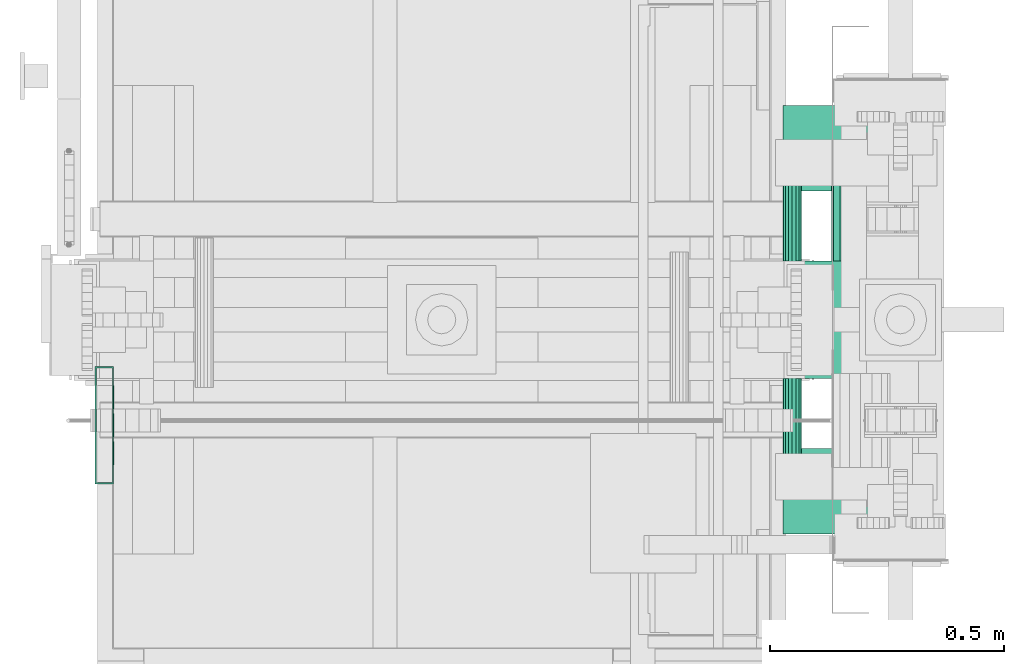
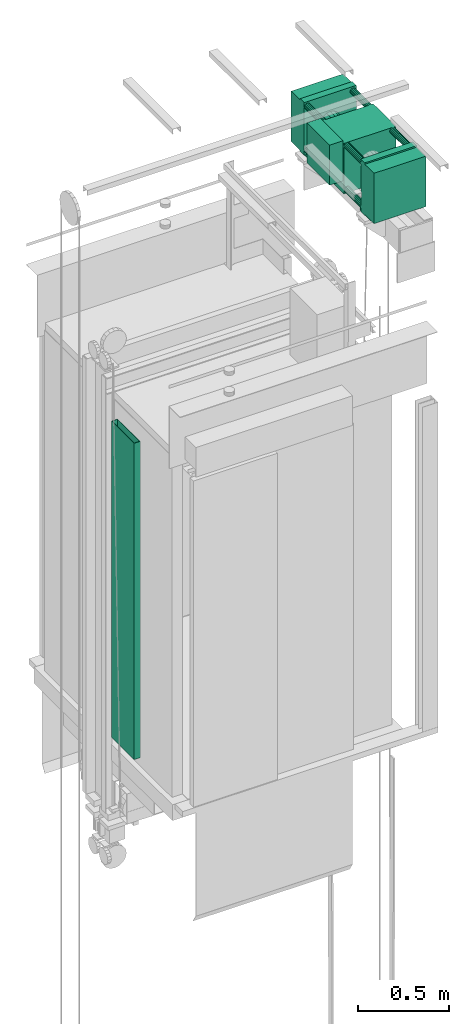
# One storey, part 3 of 13: 1 electric motor, 1 switching device.
"""IFC4 building model written with IfcOpenShell, lengths in millimetres."""

from ifc_helpers import new_model, entity, si_unit, converted_unit, frame, origin_with_axes, place, context, subcontext, project, spatial, faceted_brep, element, save


model = new_model("IFC4")

# Units and contexts
context_of_model = context(None, 3, precision=0.01, world=origin_with_axes())
sub_context_1 = subcontext(context_of_model, None, None, "MODEL_VIEW")
sub_context_2 = subcontext(context_of_model, None, None, "MODEL_VIEW")
ifc_project = project(units=[converted_unit("PLANEANGLEUNIT", "degree", entity("IfcPlaneAngleMeasure", 0.017453292519943), si_unit("PLANEANGLEUNIT", "RADIAN"), dimensions=[0, 0, 0, 0, 0, 0, 0]), si_unit("LENGTHUNIT", "METRE", prefix="MILLI"), si_unit("MASSUNIT", "GRAM", prefix="KILO"), converted_unit("TIMEUNIT", "year", entity("IfcTimeMeasure", 31557600.0), si_unit("TIMEUNIT", "SECOND"), dimensions=[0, 0, 1, 0, 0, 0, 0]), si_unit("THERMODYNAMICTEMPERATUREUNIT", "DEGREE_CELSIUS"), si_unit("AREAUNIT", "SQUARE_METRE"), si_unit("FORCEUNIT", "NEWTON"), si_unit("VOLUMEUNIT", "CUBIC_METRE"), si_unit("PRESSUREUNIT", "PASCAL"), si_unit("SOLIDANGLEUNIT", "STERADIAN")], contexts=[context_of_model])

# Site, building, storey
site = spatial("IfcSite", under=ifc_project)
building = spatial("IfcBuilding", under=site, Name="Document")
placement = place(None, origin_with_axes())
storey_placement = place(placement, frame((0.0, 0.0, -26400.0), z_axis=(0.0, 0.0, 1.0), x_axis=(1.0, 0.0, 0.0)))
storey = spatial("IfcBuildingStorey", under=building, at=storey_placement, Name="Z -26400", Elevation=-26400.0)

# Switching device
switching_device_placement = place(storey_placement, frame((200.0, 800.0, 31274.0), z_axis=(0.0, 0.0, 1.0), x_axis=(0.0, 1.0, 0.0)))
element("IfcSwitchingDevice", 1, at=switching_device_placement, inside=storey, context=sub_context_1, shape_type="Brep", body=[
    faceted_brep([(-85.0, -0.25, 1491.5), (-85.0, 0.0, 1491.5), (-85.0, 0.0, 1456.5), (-85.0, -0.25, 1456.5), (-35.0, -0.25, 1491.5), (-35.0, -0.25, 1456.5), (-35.0, 0.0, 1456.5), (-35.0, 0.0, 1491.5)], [[[0, 1, 2, 3]], [[4, 5, 6, 7]], [[0, 3, 5, 4]], [[3, 2, 6, 5]], [[2, 1, 7, 6]], [[1, 0, 4, 7]]]),
    faceted_brep([(-125.0, 20.0, 2133.0), (-122.0, 20.0, 2133.0), (-122.0, 20.0, 0.0), (-125.0, 20.0, 0.0), (-122.0, 3.0, 2133.0), (122.0, 3.0, 2133.0), (122.0, 3.0, 0.0), (-122.0, 3.0, 0.0), (125.0, 0.0, 0.0), (125.0, 0.0, 2133.0), (-125.0, 0.0, 2133.0), (-125.0, 0.0, 0.0), (122.0, 20.0, 2133.0), (125.0, 20.0, 2133.0), (125.0, 20.0, 0.0), (122.0, 20.0, 0.0)], [[[0, 1, 2, 3]], [[4, 5, 6, 7]], [[8, 9, 10, 11]], [[12, 13, 14, 15]], [[11, 10, 0, 3]], [[1, 4, 7, 2]], [[6, 5, 12, 15]], [[13, 9, 8, 14]], [[2, 7, 6, 15, 14, 8, 11, 3]], [[10, 9, 13, 12, 5, 4, 1, 0]]]),
    faceted_brep([(35.0, -0.25, 1491.5), (35.0, 0.0, 1491.5), (35.0, 0.0, 1456.5), (35.0, -0.25, 1456.5), (85.0, -0.25, 1491.5), (85.0, -0.25, 1456.5), (85.0, 0.0, 1456.5), (85.0, 0.0, 1491.5)], [[[0, 1, 2, 3]], [[4, 5, 6, 7]], [[0, 3, 5, 4]], [[3, 2, 6, 5]], [[2, 1, 7, 6]], [[1, 0, 4, 7]]]),
    faceted_brep([(-125.0, 40.0, 2133.0), (125.0, 40.0, 2133.0), (125.0, 40.0, 0.0), (-125.0, 40.0, 0.0), (122.0, 37.0, 0.0), (122.0, 37.0, 2133.0), (-122.0, 37.0, 2133.0), (-122.0, 37.0, 0.0), (-122.0, 20.0, 0.0), (-122.0, 20.0, 2133.0), (-125.0, 20.0, 2133.0), (-125.0, 20.0, 0.0), (125.0, 20.0, 0.0), (125.0, 20.0, 2133.0), (122.0, 20.0, 2133.0), (122.0, 20.0, 0.0)], [[[0, 1, 2, 3]], [[4, 5, 6, 7]], [[8, 9, 10, 11]], [[12, 13, 14, 15]], [[11, 10, 0, 3]], [[6, 9, 8, 7]], [[1, 13, 12, 2]], [[15, 14, 5, 4]], [[3, 2, 12, 15, 4, 7, 8, 11]], [[10, 9, 6, 5, 14, 13, 1, 0]]]),
    faceted_brep([(-25.0, -0.25, 1491.5), (-25.0, 0.0, 1491.5), (-25.0, 0.0, 1456.5), (-25.0, -0.25, 1456.5), (25.0, -0.25, 1491.5), (25.0, -0.25, 1456.5), (25.0, 0.0, 1456.5), (25.0, 0.0, 1491.5)], [[[0, 1, 2, 3]], [[4, 5, 6, 7]], [[0, 3, 5, 4]], [[3, 2, 6, 5]], [[2, 1, 7, 6]], [[1, 0, 4, 7]]]),
])

# Electric motor
electric_motor_placement = place(storey_placement, frame((1794.0, 810.0, 34609.0), z_axis=(0.0, 0.0, 1.0), x_axis=(-1.0, 0.0, 0.0)))
element("IfcElectricMotor", 2, at=electric_motor_placement, inside=storey, Name="Shaft0", context=sub_context_2, shape_type="Brep", body=[
    faceted_brep([(20.0, 98.0, 0.0), (18.4775390625, 98.0, -7.65234375), (14.14208984375, 98.0, -14.140625), (7.6536865234375, 98.0, -18.4765625), (0.0, 98.0, -20.0), (-7.6536865234375, 98.0, -18.4765625), (-14.14208984375, 98.0, -14.140625), (-18.4775390625, 98.0, -7.65234375), (-20.0, 98.0, 0.0), (-18.4775390625, 98.0, 7.65234375), (-14.14208984375, 98.0, 14.140625), (-7.6536865234375, 98.0, 18.4765625), (0.0, 98.0, 20.0), (7.6536865234375, 98.0, 18.4765625), (14.14208984375, 98.0, 14.140625), (18.4775390625, 98.0, 7.65234375), (20.000000000000227, -528.0, 0.0), (18.477539062500227, -528.0, 7.65234375), (14.142089843750227, -528.0, 14.140625), (7.653686523437727, -528.0, 18.4765625), (2.27e-13, -528.0, 20.0), (-7.653686523437273, -528.0, 18.4765625), (-14.142089843749773, -528.0, 14.140625), (-18.477539062499773, -528.0, 7.65234375), (-19.999999999999773, -528.0, 0.0), (-18.477539062499773, -528.0, -7.65234375), (-14.142089843749773, -528.0, -14.140625), (-7.653686523437273, -528.0, -18.4765625), (2.27e-13, -528.0, -20.0), (7.653686523437727, -528.0, -18.4765625), (14.142089843750227, -528.0, -14.140625), (18.477539062500227, -528.0, -7.65234375)], [[[0, 1, 2, 3, 4, 5, 6, 7, 8, 9, 10, 11, 12, 13, 14, 15]], [[16, 17, 18, 19, 20, 21, 22, 23, 24, 25, 26, 27, 28, 29, 30, 31]], [[0, 15, 17, 16]], [[15, 14, 18, 17]], [[14, 13, 19, 18]], [[13, 12, 20, 19]], [[12, 11, 21, 20]], [[11, 10, 22, 21]], [[10, 9, 23, 22]], [[9, 8, 24, 23]], [[8, 7, 25, 24]], [[7, 6, 26, 25]], [[6, 5, 27, 26]], [[5, 4, 28, 27]], [[4, 3, 29, 28]], [[3, 2, 30, 29]], [[2, 1, 31, 30]], [[1, 0, 16, 31]]]),
    faceted_brep([(170.0, -90.0, 190.0), (257.0, -90.0, 190.0), (257.0, -90.0, -80.0), (170.0, -90.0, -80.0), (170.00000000000023, -340.0, 190.0), (170.00000000000023, -340.0, -80.0), (257.0000000000002, -340.0, -80.0), (257.0000000000002, -340.0, 190.0)], [[[0, 1, 2, 3]], [[4, 5, 6, 7]], [[0, 3, 5, 4]], [[3, 2, 6, 5]], [[2, 1, 7, 6]], [[1, 0, 4, 7]]]),
    faceted_brep([(166.0, 98.0, 150.0), (164.4775390625, 98.0, 142.34765625), (160.14208984375, 98.0, 135.859375), (153.6536865234375, 98.0, 131.5234375), (146.0, 98.0, 130.0), (138.3463134765625, 98.0, 131.5234375), (131.85791015625, 98.0, 135.859375), (127.5224609375, 98.0, 142.34765625), (126.0, 98.0, 150.0), (127.5224609375, 98.0, 157.65234375), (131.85791015625, 98.0, 164.140625), (138.3463134765625, 98.0, 168.4765625), (146.0, 98.0, 170.0), (153.6536865234375, 98.0, 168.4765625), (160.14208984375, 98.0, 164.140625), (164.4775390625, 98.0, 157.65234375), (166.00000000000023, -528.0, 150.0), (164.47753906250023, -528.0, 157.65234375), (160.14208984375023, -528.0, 164.140625), (153.65368652343773, -528.0, 168.4765625), (146.00000000000023, -528.0, 170.0), (138.34631347656273, -528.0, 168.4765625), (131.85791015625023, -528.0, 164.140625), (127.52246093750023, -528.0, 157.65234375), (126.00000000000023, -528.0, 150.0), (127.52246093750023, -528.0, 142.34765625), (131.85791015625023, -528.0, 135.859375), (138.34631347656273, -528.0, 131.5234375), (146.00000000000023, -528.0, 130.0), (153.65368652343773, -528.0, 131.5234375), (160.14208984375023, -528.0, 135.859375), (164.47753906250023, -528.0, 142.34765625)], [[[0, 1, 2, 3, 4, 5, 6, 7, 8, 9, 10, 11, 12, 13, 14, 15]], [[16, 17, 18, 19, 20, 21, 22, 23, 24, 25, 26, 27, 28, 29, 30, 31]], [[0, 15, 17, 16]], [[15, 14, 18, 17]], [[14, 13, 19, 18]], [[13, 12, 20, 19]], [[12, 11, 21, 20]], [[11, 10, 22, 21]], [[10, 9, 23, 22]], [[9, 8, 24, 23]], [[8, 7, 25, 24]], [[7, 6, 26, 25]], [[6, 5, 27, 26]], [[5, 4, 28, 27]], [[4, 3, 29, 28]], [[3, 2, 30, 29]], [[2, 1, 31, 30]], [[1, 0, 16, 31]]]),
    faceted_brep([(166.00000000000023, -572.0, 180.0), (-165.99999999999977, -572.0, 180.0), (-165.99999999999977, -572.0, -175.0), (166.00000000000023, -572.0, -175.0), (166.00000000000023, -528.0, 180.0), (166.00000000000023, -528.0, -175.0), (-165.99999999999977, -528.0, -175.0), (-165.99999999999977, -528.0, 180.0)], [[[0, 1, 2, 3]], [[4, 5, 6, 7]], [[0, 3, 5, 4]], [[3, 2, 6, 5]], [[2, 1, 7, 6]], [[1, 0, 4, 7]]]),
    faceted_brep([(166.0, 142.0, 170.0), (-166.0, 142.0, 170.0), (-166.0, 142.0, -170.0), (166.0, 142.0, -170.0), (166.0, 242.0, 170.0), (166.0, 242.0, -170.0), (-166.0, 242.0, -170.0), (-166.0, 242.0, 170.0)], [[[0, 1, 2, 3]], [[4, 5, 6, 7]], [[0, 3, 5, 4]], [[3, 2, 6, 5]], [[2, 1, 7, 6]], [[1, 0, 4, 7]]]),
    faceted_brep([(166.0, 98.0, -145.0), (164.4775390625, 98.0, -152.65234375), (160.14208984375, 98.0, -159.140625), (153.6536865234375, 98.0, -163.4765625), (146.0, 98.0, -165.0), (138.3463134765625, 98.0, -163.4765625), (131.85791015625, 98.0, -159.140625), (127.5224609375, 98.0, -152.65234375), (126.0, 98.0, -145.0), (127.5224609375, 98.0, -137.34765625), (131.85791015625, 98.0, -130.859375), (138.3463134765625, 98.0, -126.5234375), (146.0, 98.0, -125.0), (153.6536865234375, 98.0, -126.5234375), (160.14208984375, 98.0, -130.859375), (164.4775390625, 98.0, -137.34765625), (166.00000000000023, -528.0, -145.0), (164.47753906250023, -528.0, -137.34765625), (160.14208984375023, -528.0, -130.859375), (153.65368652343773, -528.0, -126.5234375), (146.00000000000023, -528.0, -125.0), (138.34631347656273, -528.0, -126.5234375), (131.85791015625023, -528.0, -130.859375), (127.52246093750023, -528.0, -137.34765625), (126.00000000000023, -528.0, -145.0), (127.52246093750023, -528.0, -152.65234375), (131.85791015625023, -528.0, -159.140625), (138.34631347656273, -528.0, -163.4765625), (146.00000000000023, -528.0, -165.0), (153.65368652343773, -528.0, -163.4765625), (160.14208984375023, -528.0, -159.140625), (164.47753906250023, -528.0, -152.65234375)], [[[0, 1, 2, 3, 4, 5, 6, 7, 8, 9, 10, 11, 12, 13, 14, 15]], [[16, 17, 18, 19, 20, 21, 22, 23, 24, 25, 26, 27, 28, 29, 30, 31]], [[0, 15, 17, 16]], [[15, 14, 18, 17]], [[14, 13, 19, 18]], [[13, 12, 20, 19]], [[12, 11, 21, 20]], [[11, 10, 22, 21]], [[10, 9, 23, 22]], [[9, 8, 24, 23]], [[8, 7, 25, 24]], [[7, 6, 26, 25]], [[6, 5, 27, 26]], [[5, 4, 28, 27]], [[4, 3, 29, 28]], [[3, 2, 30, 29]], [[2, 1, 31, 30]], [[1, 0, 16, 31]]]),
    faceted_brep([(166.00000000000023, -340.0, 170.0), (-165.99999999999977, -340.0, 170.0), (-165.99999999999977, -340.0, -170.0), (166.00000000000023, -340.0, -170.0), (166.0, -90.0, 170.0), (166.0, -90.0, -170.0), (-166.0, -90.0, -170.0), (-166.0, -90.0, 170.0)], [[[0, 1, 2, 3]], [[4, 5, 6, 7]], [[0, 3, 5, 4]], [[3, 2, 6, 5]], [[2, 1, 7, 6]], [[1, 0, 4, 7]]]),
    faceted_brep([(50.0, 60.0, -175.0), (50.0, 180.0, -175.0), (50.0, 180.0, -195.0), (50.0, 60.0, -195.0), (150.0, 60.0, -175.0), (150.0, 60.0, -195.0), (150.0, 180.0, -195.0), (150.0, 180.0, -175.0)], [[[0, 1, 2, 3]], [[4, 5, 6, 7]], [[0, 3, 5, 4]], [[3, 2, 6, 5]], [[2, 1, 7, 6]], [[1, 0, 4, 7]]]),
    faceted_brep([(2.27e-13, -530.0, 62.5), (-23.917724609374773, -530.0, 57.7421875), (-44.19421386718727, -530.0, 44.1953125), (-57.74243164062477, -530.0, 23.91796875), (-62.49999999999977, -530.0, 0.0), (-57.74243164062477, -530.0, -23.91796875), (-44.19421386718727, -530.0, -44.1953125), (-23.917724609374773, -530.0, -57.7421875), (2.27e-13, -530.0, -62.5), (23.917724609375227, -530.0, -57.7421875), (44.19421386718773, -530.0, -44.1953125), (57.74243164062523, -530.0, -23.91796875), (62.50000000000023, -530.0, 0.0), (57.74243164062523, -530.0, 23.91796875), (44.19421386718773, -530.0, 44.1953125), (23.917724609375227, -530.0, 57.7421875), (2.27e-13, -330.0, 62.5), (23.917724609375227, -330.0, 57.7421875), (44.19421386718773, -330.0, 44.1953125), (57.74243164062523, -330.0, 23.91796875), (62.50000000000023, -330.0, 0.0), (57.74243164062523, -330.0, -23.91796875), (44.19421386718773, -330.0, -44.1953125), (23.917724609375227, -330.0, -57.7421875), (2.27e-13, -330.0, -62.5), (-23.917724609374773, -330.0, -57.7421875), (-44.19421386718727, -330.0, -44.1953125), (-57.74243164062477, -330.0, -23.91796875), (-62.49999999999977, -330.0, 0.0), (-57.74243164062477, -330.0, 23.91796875), (-44.19421386718727, -330.0, 44.1953125), (-23.917724609374773, -330.0, 57.7421875)], [[[0, 1, 2, 3, 4, 5, 6, 7, 8, 9, 10, 11, 12, 13, 14, 15]], [[16, 17, 18, 19, 20, 21, 22, 23, 24, 25, 26, 27, 28, 29, 30, 31]], [[0, 15, 17, 16]], [[15, 14, 18, 17]], [[14, 13, 19, 18]], [[13, 12, 20, 19]], [[12, 11, 21, 20]], [[11, 10, 22, 21]], [[10, 9, 23, 22]], [[9, 8, 24, 23]], [[8, 7, 25, 24]], [[7, 6, 26, 25]], [[6, 5, 27, 26]], [[5, 4, 28, 27]], [[4, 3, 29, 28]], [[3, 2, 30, 29]], [[2, 1, 31, 30]], [[1, 0, 16, 31]]]),
    faceted_brep([(-149.99999999999977, -610.0, -175.0), (-149.99999999999977, -490.0, -175.0), (-149.99999999999977, -490.0, -195.0), (-149.99999999999977, -610.0, -195.0), (-49.99999999999977, -610.0, -175.0), (-49.99999999999977, -610.0, -195.0), (-49.99999999999977, -490.0, -195.0), (-49.99999999999977, -490.0, -175.0)], [[[0, 1, 2, 3]], [[4, 5, 6, 7]], [[0, 3, 5, 4]], [[3, 2, 6, 5]], [[2, 1, 7, 6]], [[1, 0, 4, 7]]]),
    faceted_brep([(50.00000000000023, -610.0, -175.0), (50.00000000000023, -490.0, -175.0), (50.00000000000023, -490.0, -195.0), (50.00000000000023, -610.0, -195.0), (150.00000000000023, -610.0, -175.0), (150.00000000000023, -610.0, -195.0), (150.00000000000023, -490.0, -195.0), (150.00000000000023, -490.0, -175.0)], [[[0, 1, 2, 3]], [[4, 5, 6, 7]], [[0, 3, 5, 4]], [[3, 2, 6, 5]], [[2, 1, 7, 6]], [[1, 0, 4, 7]]]),
    faceted_brep([(166.00000000000023, -672.0, 170.0), (-165.99999999999977, -672.0, 170.0), (-165.99999999999977, -672.0, -170.0), (166.00000000000023, -672.0, -170.0), (166.00000000000023, -572.0, 170.0), (166.00000000000023, -572.0, -170.0), (-165.99999999999977, -572.0, -170.0), (-165.99999999999977, -572.0, 170.0)], [[[0, 1, 2, 3]], [[4, 5, 6, 7]], [[0, 3, 5, 4]], [[3, 2, 6, 5]], [[2, 1, 7, 6]], [[1, 0, 4, 7]]]),
    faceted_brep([(166.0, 98.0, 180.0), (-166.0, 98.0, 180.0), (-166.0, 98.0, -175.0), (166.0, 98.0, -175.0), (166.0, 142.0, 180.0), (166.0, 142.0, -175.0), (-166.0, 142.0, -175.0), (-166.0, 142.0, 180.0)], [[[0, 1, 2, 3]], [[4, 5, 6, 7]], [[0, 3, 5, 4]], [[3, 2, 6, 5]], [[2, 1, 7, 6]], [[1, 0, 4, 7]]]),
    faceted_brep([(-126.0, 98.0, 150.0), (-127.5224609375, 98.0, 142.34765625), (-131.85791015625, 98.0, 135.859375), (-138.3463134765625, 98.0, 131.5234375), (-146.0, 98.0, 130.0), (-153.6536865234375, 98.0, 131.5234375), (-160.14208984375, 98.0, 135.859375), (-164.4775390625, 98.0, 142.34765625), (-166.0, 98.0, 150.0), (-164.4775390625, 98.0, 157.65234375), (-160.14208984375, 98.0, 164.140625), (-153.6536865234375, 98.0, 168.4765625), (-146.0, 98.0, 170.0), (-138.3463134765625, 98.0, 168.4765625), (-131.85791015625, 98.0, 164.140625), (-127.5224609375, 98.0, 157.65234375), (-125.99999999999977, -528.0, 150.0), (-127.52246093749977, -528.0, 157.65234375), (-131.85791015624977, -528.0, 164.140625), (-138.34631347656227, -528.0, 168.4765625), (-145.99999999999977, -528.0, 170.0), (-153.65368652343727, -528.0, 168.4765625), (-160.14208984374977, -528.0, 164.140625), (-164.47753906249977, -528.0, 157.65234375), (-165.99999999999977, -528.0, 150.0), (-164.47753906249977, -528.0, 142.34765625), (-160.14208984374977, -528.0, 135.859375), (-153.65368652343727, -528.0, 131.5234375), (-145.99999999999977, -528.0, 130.0), (-138.34631347656227, -528.0, 131.5234375), (-131.85791015624977, -528.0, 135.859375), (-127.52246093749977, -528.0, 142.34765625)], [[[0, 1, 2, 3, 4, 5, 6, 7, 8, 9, 10, 11, 12, 13, 14, 15]], [[16, 17, 18, 19, 20, 21, 22, 23, 24, 25, 26, 27, 28, 29, 30, 31]], [[0, 15, 17, 16]], [[15, 14, 18, 17]], [[14, 13, 19, 18]], [[13, 12, 20, 19]], [[12, 11, 21, 20]], [[11, 10, 22, 21]], [[10, 9, 23, 22]], [[9, 8, 24, 23]], [[8, 7, 25, 24]], [[7, 6, 26, 25]], [[6, 5, 27, 26]], [[5, 4, 28, 27]], [[4, 3, 29, 28]], [[3, 2, 30, 29]], [[2, 1, 31, 30]], [[1, 0, 16, 31]]]),
    faceted_brep([(-126.0, 98.0, -145.0), (-127.5224609375, 98.0, -152.65234375), (-131.85791015625, 98.0, -159.140625), (-138.3463134765625, 98.0, -163.4765625), (-146.0, 98.0, -165.0), (-153.6536865234375, 98.0, -163.4765625), (-160.14208984375, 98.0, -159.140625), (-164.4775390625, 98.0, -152.65234375), (-166.0, 98.0, -145.0), (-164.4775390625, 98.0, -137.34765625), (-160.14208984375, 98.0, -130.859375), (-153.6536865234375, 98.0, -126.5234375), (-146.0, 98.0, -125.0), (-138.3463134765625, 98.0, -126.5234375), (-131.85791015625, 98.0, -130.859375), (-127.5224609375, 98.0, -137.34765625), (-125.99999999999977, -528.0, -145.0), (-127.52246093749977, -528.0, -137.34765625), (-131.85791015624977, -528.0, -130.859375), (-138.34631347656227, -528.0, -126.5234375), (-145.99999999999977, -528.0, -125.0), (-153.65368652343727, -528.0, -126.5234375), (-160.14208984374977, -528.0, -130.859375), (-164.47753906249977, -528.0, -137.34765625), (-165.99999999999977, -528.0, -145.0), (-164.47753906249977, -528.0, -152.65234375), (-160.14208984374977, -528.0, -159.140625), (-153.65368652343727, -528.0, -163.4765625), (-145.99999999999977, -528.0, -165.0), (-138.34631347656227, -528.0, -163.4765625), (-131.85791015624977, -528.0, -159.140625), (-127.52246093749977, -528.0, -152.65234375)], [[[0, 1, 2, 3, 4, 5, 6, 7, 8, 9, 10, 11, 12, 13, 14, 15]], [[16, 17, 18, 19, 20, 21, 22, 23, 24, 25, 26, 27, 28, 29, 30, 31]], [[0, 15, 17, 16]], [[15, 14, 18, 17]], [[14, 13, 19, 18]], [[13, 12, 20, 19]], [[12, 11, 21, 20]], [[11, 10, 22, 21]], [[10, 9, 23, 22]], [[9, 8, 24, 23]], [[8, 7, 25, 24]], [[7, 6, 26, 25]], [[6, 5, 27, 26]], [[5, 4, 28, 27]], [[4, 3, 29, 28]], [[3, 2, 30, 29]], [[2, 1, 31, 30]], [[1, 0, 16, 31]]]),
    faceted_brep([(-150.0, 60.0, -175.0), (-150.0, 180.0, -175.0), (-150.0, 180.0, -195.0), (-150.0, 60.0, -195.0), (-50.0, 60.0, -175.0), (-50.0, 60.0, -195.0), (-50.0, 180.0, -195.0), (-50.0, 180.0, -175.0)], [[[0, 1, 2, 3]], [[4, 5, 6, 7]], [[0, 3, 5, 4]], [[3, 2, 6, 5]], [[2, 1, 7, 6]], [[1, 0, 4, 7]]]),
])

save(model, "model.ifc")
